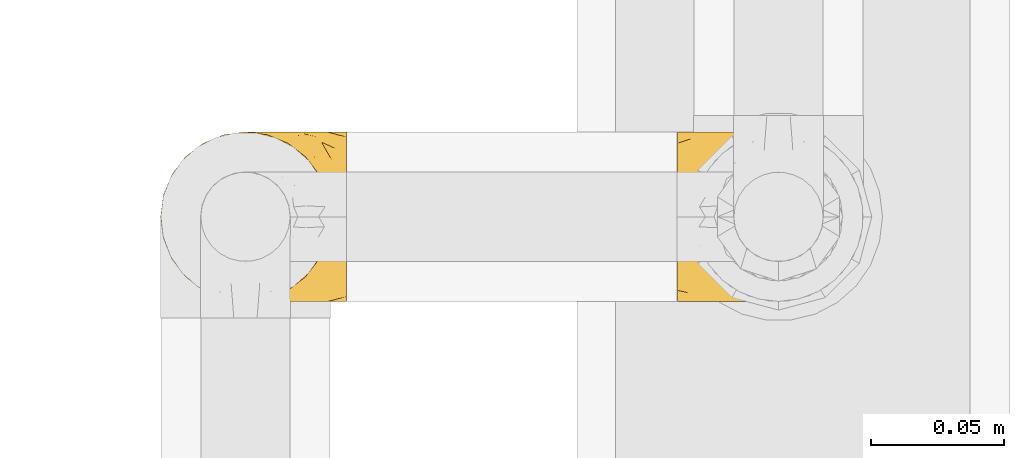
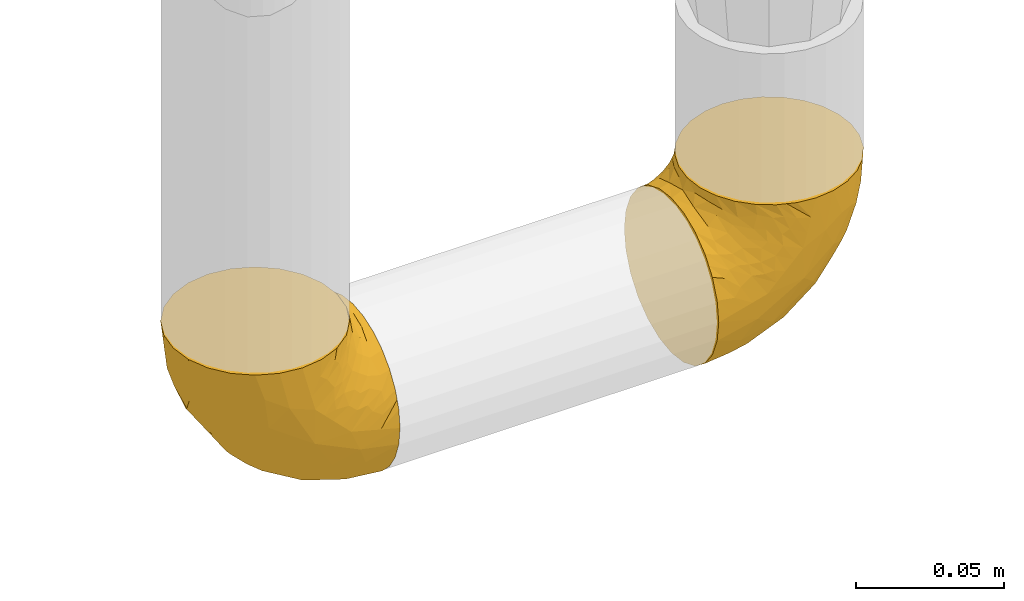
# One storey, part 505 of 827: 2 coverings.
"""IFC2X3 building model written with IfcOpenShell, lengths in millimetres."""

from ifc_helpers import new_model, entity, si_unit, converted_unit, derived_unit, direction, frame, origin, place, context, subcontext, project, spatial, faceted_brep, element, save


model = new_model("IFC2X3")

# Units and contexts
model_context = context("Model", 3, precision=0.01, world=origin(), true_north=direction((6.12303176911189e-17, 1.0)))
body_context = subcontext(model_context, "Body", "Model", "MODEL_VIEW")
ifc_project = project(units=[si_unit("LENGTHUNIT", "METRE", prefix="MILLI"), si_unit("AREAUNIT", "SQUARE_METRE"), si_unit("VOLUMEUNIT", "CUBIC_METRE"), converted_unit("PLANEANGLEUNIT", "DEGREE", entity("IfcRatioMeasure", 0.0174532925199433), si_unit("PLANEANGLEUNIT", "RADIAN"), dimensions=[0, 0, 0, 0, 0, 0, 0]), si_unit("MASSUNIT", "GRAM", prefix="KILO"), derived_unit("MASSDENSITYUNIT", [(si_unit("MASSUNIT", "GRAM", prefix="KILO"), 1), (si_unit("LENGTHUNIT", "METRE"), -3)]), derived_unit("MOMENTOFINERTIAUNIT", [(si_unit("LENGTHUNIT", "METRE"), 4)]), si_unit("TIMEUNIT", "SECOND"), si_unit("FREQUENCYUNIT", "HERTZ"), si_unit("THERMODYNAMICTEMPERATUREUNIT", "DEGREE_CELSIUS"), derived_unit("THERMALTRANSMITTANCEUNIT", [(si_unit("MASSUNIT", "GRAM", prefix="KILO"), 1), (si_unit("THERMODYNAMICTEMPERATUREUNIT", "KELVIN"), -1), (si_unit("TIMEUNIT", "SECOND"), -3)]), derived_unit("VOLUMETRICFLOWRATEUNIT", [(si_unit("LENGTHUNIT", "METRE"), 3), (si_unit("TIMEUNIT", "SECOND"), -1)]), derived_unit("MASSFLOWRATEUNIT", [(si_unit("MASSUNIT", "GRAM", prefix="KILO"), 1), (si_unit("TIMEUNIT", "SECOND"), -1)]), derived_unit("ROTATIONALFREQUENCYUNIT", [(si_unit("TIMEUNIT", "SECOND"), -1)]), si_unit("ELECTRICCURRENTUNIT", "AMPERE"), si_unit("ELECTRICVOLTAGEUNIT", "VOLT"), si_unit("POWERUNIT", "WATT"), si_unit("FORCEUNIT", "NEWTON", prefix="KILO"), si_unit("ILLUMINANCEUNIT", "LUX"), si_unit("LUMINOUSFLUXUNIT", "LUMEN"), si_unit("LUMINOUSINTENSITYUNIT", "CANDELA"), derived_unit("USERDEFINED", [(si_unit("MASSUNIT", "GRAM", prefix="KILO"), -1), (si_unit("LENGTHUNIT", "METRE"), -2), (si_unit("TIMEUNIT", "SECOND"), 3), (si_unit("LUMINOUSFLUXUNIT", "LUMEN"), 1)]), derived_unit("LINEARVELOCITYUNIT", [(si_unit("LENGTHUNIT", "METRE"), 1), (si_unit("TIMEUNIT", "SECOND"), -1)]), si_unit("PRESSUREUNIT", "PASCAL"), derived_unit("USERDEFINED", [(si_unit("LENGTHUNIT", "METRE"), -2), (si_unit("MASSUNIT", "GRAM", prefix="KILO"), 1), (si_unit("TIMEUNIT", "SECOND"), -2)]), derived_unit("LINEARFORCEUNIT", [(si_unit("MASSUNIT", "GRAM", prefix="KILO"), 1), (si_unit("LENGTHUNIT", "METRE"), 1), (si_unit("TIMEUNIT", "SECOND"), -2), (si_unit("LENGTHUNIT", "METRE"), -1)]), derived_unit("PLANARFORCEUNIT", [(si_unit("MASSUNIT", "GRAM", prefix="KILO"), 1), (si_unit("LENGTHUNIT", "METRE"), 1), (si_unit("TIMEUNIT", "SECOND"), -2), (si_unit("LENGTHUNIT", "METRE"), -2)])], contexts=[model_context])

# Site, building, storey
site_placement = place(None, origin())
site = spatial("IfcSite", under=ifc_project, at=site_placement, CompositionType="ELEMENT")
building_placement = place(site_placement, origin())
building = spatial("IfcBuilding", under=site, at=building_placement, CompositionType="ELEMENT")
storey_placement = place(building_placement, frame((0.0, 0.0, 28200.0)))
storey = spatial("IfcBuildingStorey", under=building, at=storey_placement, Name="08", CompositionType="ELEMENT", Elevation=28200.0)

# Coverings
covering_1_placement = place(storey_placement, frame((59919.69, 17466.55, 366.55)))
element("IfcCovering", 1, at=covering_1_placement, inside=storey, Name=":ADSK_", ObjectType=":ADSK_", PredefinedType="INSULATION", context=body_context, shape_type="Brep", body=[
    faceted_brep([(71.45, 26.36, 2.39), (71.45, 33.45, 1.6), (71.45, 40.54, 2.39), (71.45, 47.27, 4.75), (71.45, 53.31, 8.55), (71.45, 58.35, 13.59), (71.45, 62.14, 19.63), (71.45, 64.5, 26.36), (71.45, 65.3, 33.45), (71.45, 64.86, 37.35), (71.45, 64.5, 40.54), (71.45, 63.32, 43.9), (71.45, 62.14, 47.27), (71.45, 58.34, 53.31), (71.45, 53.3, 58.35), (71.45, 47.26, 62.14), (71.45, 40.53, 64.5), (71.45, 33.45, 65.3), (71.45, 26.35, 64.5), (71.45, 19.62, 62.14), (71.45, 13.58, 58.34), (71.45, 8.54, 53.3), (71.45, 4.75, 47.26), (71.45, 3.57, 43.89), (71.45, 2.39, 40.53), (71.45, 2.03, 37.35), (71.45, 1.81, 35.4), (71.45, 1.6, 33.45), (71.45, 2.39, 26.35), (71.45, 4.75, 19.62), (71.45, 8.55, 13.58), (71.45, 13.59, 8.54), (71.45, 19.63, 4.75), (49.37, 61.03, 71.45), (45.53, 62.62, 71.45), (41.69, 64.21, 71.45), (37.37, 64.78, 71.45), (35.41, 65.04, 71.45), (33.45, 65.3, 71.45), (25.2, 64.21, 71.45), (17.52, 61.03, 71.45), (10.92, 55.97, 71.45), (5.86, 49.37, 71.45), (2.68, 41.69, 71.45), (1.6, 33.45, 71.45), (2.68, 25.2, 71.45), (5.86, 17.52, 71.45), (10.92, 10.92, 71.45), (17.52, 5.86, 71.45), (25.2, 2.68, 71.45), (33.45, 1.6, 71.45), (37.37, 2.11, 71.45), (41.69, 2.68, 71.45), (45.53, 4.27, 71.45), (49.37, 5.86, 71.45), (52.67, 8.39, 71.45), (55.97, 10.92, 71.45), (61.03, 17.52, 71.45), (64.21, 25.2, 71.45), (65.3, 33.45, 71.45), (64.21, 41.69, 71.45), (61.03, 49.37, 71.45), (55.97, 55.97, 71.45), (52.67, 58.5, 71.45), (39.1, 2.87, 37.48), (52.45, 1.6, 38.54), (48.97, 1.6, 42.01), (45.49, 1.6, 45.49), (42.01, 1.6, 48.97), (38.54, 1.6, 52.45), (4.25, 33.45, 58.08), (19.42, 10.76, 40.84), (22.87, 5.89, 47.91), (14.43, 9.64, 55.67), (5.53, 22.45, 55.18), (12.01, 16.56, 45.13), (8.54, 15.17, 59.19), (55.06, 12.49, 11.67), (11.33, 25.02, 38.17), (20.79, 18.64, 28.82), (56.32, 2.29, 29.48), (33.95, 6.11, 32.11), (47.18, 5.18, 24.68), (28.97, 2.43, 55.82), (28.68, 11.11, 28.37), (41.69, 26.19, 9.18), (55.32, 24.02, 4.95), (43.59, 19.02, 11.17), (20.67, 4.77, 60.89), (37.76, 1.6, 55.35), (36.98, 1.6, 58.25), (36.2, 1.6, 61.15), (35.43, 1.6, 64.05), (34.93, 1.6, 65.9), (34.44, 1.6, 67.75), (58.97, 7.57, 16.27), (59.39, 17.54, 6.97), (58.08, 33.45, 4.25), (59.72, 4.36, 21.84), (69.6, 1.6, 33.94), (67.75, 1.6, 34.44), (64.05, 1.6, 35.43), (61.15, 1.6, 36.2), (58.25, 1.6, 36.98), (55.35, 1.6, 37.76), (43.85, 9.86, 18.84), (44.13, 14.05, 14.39), (4.87, 28.37, 51.68), (44.71, 33.45, 6.91), (19.59, 25.8, 26.05), (14.48, 33.45, 33.38), (22.05, 33.45, 22.05), (29.9, 22.54, 17.7), (33.81, 15.6, 19.21), (6.91, 33.45, 44.71), (27.44, 28.45, 17.7), (33.38, 33.45, 14.48), (55.01, 9.47, 66.98), (50.28, 5.83, 65.01), (51.09, 5.65, 61.98), (40.86, 2.31, 64.85), (43.96, 2.89, 62.15), (52.27, 2.68, 48.67), (68.29, 22.04, 63.81), (62.01, 5.47, 50.71), (66.26, 5.05, 48.45), (67.36, 7.86, 52.85), (65.34, 25.25, 67.6), (68.62, 28.09, 65.48), (67.1, 33.45, 67.1), (58.52, 12.77, 66.68), (61.41, 2.62, 43.2), (66.44, 3.56, 44.92), (65.71, 11.92, 58.1), (60.56, 11.98, 61.92), (65.05, 17.45, 63.17), (61.9, 17.1, 66.68), (58.97, 7.66, 56.7), (57.67, 4.47, 50.86), (62.23, 7.62, 54.42), (65.15, 2.29, 40.7), (46.86, 3.16, 57.76), (67.24, 16.64, 61.34), (63.1, 12.23, 59.9), (50.81, 4.54, 58.0), (54.65, 7.84, 62.43), (55.33, 2.55, 45.83), (56.17, 7.37, 58.99), (59.8, 3.18, 45.9), (48.09, 4.97, 67.3), (46.45, 2.38, 53.12), (46.88, 1.99, 49.43), (50.93, 3.56, 53.9), (55.61, 4.66, 52.92), (68.29, 44.85, 63.81), (67.24, 50.24, 61.35), (65.05, 49.43, 63.17), (58.97, 59.23, 56.72), (62.98, 54.76, 59.87), (61.5, 59.54, 54.39), (65.34, 41.64, 67.59), (65.15, 64.6, 40.71), (64.05, 65.3, 35.43), (61.15, 65.3, 36.2), (58.25, 65.3, 36.98), (68.62, 38.79, 65.48), (50.62, 62.38, 58.19), (45.09, 64.44, 55.78), (50.82, 61.27, 62.46), (33.94, 65.3, 69.6), (36.2, 65.3, 61.15), (35.43, 65.3, 64.05), (34.44, 65.3, 67.75), (51.55, 59.93, 67.39), (46.52, 62.73, 66.16), (54.95, 60.51, 58.11), (54.65, 59.05, 62.44), (59.16, 56.02, 61.95), (61.9, 49.79, 66.68), (40.86, 64.58, 64.85), (38.54, 65.3, 52.45), (42.01, 65.3, 48.97), (61.39, 64.27, 43.18), (67.37, 59.01, 52.88), (66.23, 61.84, 48.46), (67.75, 65.3, 34.44), (65.9, 65.3, 34.93), (65.7, 54.97, 58.11), (36.98, 65.3, 58.25), (41.66, 64.66, 60.72), (53.21, 63.94, 49.13), (45.49, 65.3, 45.49), (50.1, 63.6, 53.71), (66.44, 63.33, 44.93), (55.11, 57.32, 67.04), (58.52, 54.15, 66.6), (55.59, 64.5, 44.91), (62.01, 61.42, 50.72), (55.35, 65.3, 37.76), (52.45, 65.3, 38.54), (60.71, 63.43, 46.39), (42.77, 64.69, 57.7), (37.76, 65.3, 55.35), (47.15, 62.87, 62.73), (48.97, 65.3, 42.01), (14.42, 57.25, 55.67), (59.72, 62.54, 21.85), (56.32, 64.6, 29.49), (28.97, 64.46, 55.82), (11.33, 41.87, 38.17), (5.53, 44.44, 55.18), (12.01, 50.33, 45.12), (22.86, 61.0, 47.92), (39.12, 64.03, 37.47), (33.96, 60.79, 32.11), (19.42, 56.13, 40.85), (4.87, 38.52, 51.68), (20.67, 62.12, 60.89), (8.55, 51.72, 59.19), (47.18, 61.71, 24.69), (58.97, 59.33, 16.28), (43.86, 57.04, 18.85), (43.58, 47.88, 11.19), (55.32, 42.88, 4.95), (41.67, 40.71, 9.19), (55.05, 54.41, 11.68), (19.59, 41.09, 26.05), (33.79, 51.29, 19.23), (44.12, 52.85, 14.4), (59.39, 49.36, 6.97), (20.81, 48.25, 28.8), (29.91, 44.35, 17.7), (28.68, 55.79, 28.37), (27.45, 38.44, 17.7)], [[[0, 1, 2, 3, 4, 5, 6, 7, 8, 9, 10, 11, 12, 13, 14, 15, 16, 17, 18, 19, 20, 21, 22, 23, 24, 25, 26, 27, 28, 29, 30, 31, 32]], [[33, 34, 35, 36, 37, 38, 39, 40, 41, 42, 43, 44, 45, 46, 47, 48, 49, 50, 51, 52, 53, 54, 55, 56, 57, 58, 59, 60, 61, 62, 63]], [[64, 65, 66, 67, 68, 69]], [[45, 44, 70]], [[71, 72, 73]], [[74, 75, 76]], [[77, 31, 30]], [[75, 78, 79]], [[27, 80, 28]], [[74, 46, 45]], [[64, 81, 82]], [[46, 76, 47]], [[83, 50, 49]], [[48, 47, 73]], [[71, 79, 84]], [[85, 86, 87]], [[49, 48, 88]], [[83, 69, 89, 90, 91, 92, 93, 94, 50]], [[95, 77, 30]], [[75, 74, 78]], [[87, 86, 96]], [[96, 86, 32]], [[96, 32, 31]], [[0, 86, 97]], [[83, 64, 69]], [[98, 80, 82]], [[73, 72, 88]], [[64, 80, 65]], [[1, 0, 97]], [[80, 27, 99, 100, 101, 102, 103, 104, 65]], [[77, 105, 106]], [[64, 82, 80]], [[70, 107, 45]], [[77, 95, 105]], [[82, 95, 98]], [[95, 30, 29]], [[74, 107, 78]], [[86, 0, 32]], [[72, 71, 81]], [[85, 108, 86]], [[76, 73, 47]], [[71, 84, 81]], [[109, 110, 111]], [[87, 112, 85]], [[79, 109, 112]], [[79, 112, 113]], [[88, 83, 49]], [[64, 83, 72]], [[31, 77, 96]], [[87, 96, 77]], [[98, 95, 29]], [[105, 95, 82]], [[81, 105, 82]], [[105, 84, 113]], [[29, 28, 98]], [[114, 107, 70]], [[80, 98, 28]], [[73, 75, 71]], [[79, 71, 75]], [[74, 76, 46]], [[73, 76, 75]], [[78, 107, 114]], [[45, 107, 74]], [[87, 113, 112]], [[115, 85, 112]], [[109, 79, 78]], [[113, 87, 106]], [[116, 115, 111]], [[116, 108, 85]], [[79, 113, 84]], [[109, 78, 110]], [[115, 109, 111]], [[85, 115, 116]], [[109, 115, 112]], [[72, 81, 64]], [[105, 81, 84]], [[73, 88, 48]], [[83, 88, 72]], [[86, 108, 97]], [[78, 114, 110]], [[113, 106, 105]], [[87, 77, 106]], [[117, 118, 119]], [[52, 120, 54, 53]], [[91, 120, 52]], [[91, 90, 120]], [[90, 121, 120]], [[122, 67, 66]], [[18, 123, 19]], [[124, 125, 126]], [[127, 59, 58]], [[128, 129, 127]], [[130, 57, 117]], [[131, 132, 125]], [[19, 133, 20]], [[128, 18, 17]], [[134, 135, 136]], [[137, 138, 139]], [[131, 103, 140]], [[22, 140, 23]], [[131, 65, 104, 103]], [[26, 25, 24, 101, 100, 99, 27]], [[141, 118, 121]], [[19, 123, 142]], [[52, 51, 50, 94, 93, 92, 91]], [[129, 128, 17]], [[117, 56, 118]], [[135, 134, 143]], [[139, 126, 133]], [[119, 144, 145]], [[127, 135, 123]], [[136, 58, 57]], [[101, 24, 23]], [[124, 138, 146]], [[140, 101, 23]], [[145, 147, 134]], [[140, 132, 131]], [[140, 103, 102, 101]], [[140, 22, 132]], [[146, 148, 124]], [[121, 69, 141]], [[55, 149, 118]], [[150, 151, 152]], [[147, 137, 134]], [[144, 150, 152]], [[152, 151, 122]], [[138, 122, 146]], [[59, 127, 129]], [[123, 18, 128]], [[58, 136, 127]], [[135, 127, 136]], [[121, 90, 89, 69]], [[120, 121, 149]], [[122, 66, 146]], [[153, 122, 138]], [[141, 69, 68]], [[127, 123, 128]], [[123, 135, 142]], [[143, 142, 135]], [[19, 142, 133]], [[66, 65, 146]], [[148, 65, 131]], [[22, 21, 132]], [[125, 132, 21]], [[126, 125, 21]], [[148, 125, 124]], [[21, 20, 126]], [[133, 126, 20]], [[139, 138, 124]], [[153, 138, 137]], [[126, 139, 124]], [[139, 133, 143]], [[147, 153, 137]], [[152, 122, 153]], [[134, 136, 130]], [[137, 139, 143]], [[144, 147, 145]], [[153, 147, 152]], [[65, 148, 146]], [[125, 148, 131]], [[141, 144, 119]], [[55, 54, 149]], [[137, 143, 134]], [[142, 143, 133]], [[130, 117, 145]], [[57, 56, 117]], [[134, 130, 145]], [[57, 130, 136]], [[150, 144, 141]], [[147, 144, 152]], [[141, 68, 150]], [[151, 68, 67]], [[117, 119, 145]], [[141, 119, 118]], [[68, 151, 150]], [[122, 151, 67]], [[118, 56, 55]], [[120, 149, 54]], [[118, 149, 121]], [[154, 155, 156]], [[157, 158, 159]], [[129, 160, 59]], [[161, 162, 163, 164]], [[165, 160, 129]], [[166, 167, 168]], [[169, 38, 37, 36, 35, 170, 171, 172]], [[63, 173, 174]], [[175, 176, 177]], [[60, 178, 61]], [[179, 35, 34, 33]], [[160, 60, 59]], [[180, 167, 181]], [[129, 17, 165]], [[182, 161, 164]], [[183, 13, 184]], [[9, 8, 185, 186, 162, 10]], [[187, 155, 15]], [[188, 179, 189]], [[187, 15, 14]], [[190, 191, 192]], [[182, 193, 161]], [[194, 176, 168]], [[176, 195, 177]], [[196, 190, 197]], [[11, 10, 162]], [[11, 161, 12]], [[187, 14, 183]], [[12, 161, 193]], [[156, 158, 177]], [[165, 17, 16]], [[194, 195, 176]], [[187, 159, 158]], [[179, 174, 189]], [[182, 164, 198, 199]], [[200, 199, 196]], [[193, 184, 13]], [[194, 168, 173]], [[201, 202, 189]], [[16, 154, 165]], [[160, 156, 178]], [[160, 165, 154]], [[178, 60, 160]], [[170, 35, 179]], [[188, 170, 179]], [[189, 174, 203]], [[174, 179, 33]], [[201, 189, 203]], [[181, 192, 191]], [[167, 180, 201]], [[192, 175, 190]], [[159, 190, 157]], [[15, 154, 16]], [[204, 196, 199]], [[204, 191, 190]], [[160, 154, 156]], [[15, 155, 154]], [[158, 155, 187]], [[203, 173, 168]], [[192, 181, 167]], [[190, 196, 204]], [[200, 196, 197]], [[184, 193, 182]], [[13, 12, 193]], [[200, 184, 182]], [[184, 200, 183]], [[187, 183, 197]], [[14, 13, 183]], [[162, 161, 11]], [[63, 62, 173]], [[174, 33, 63]], [[173, 62, 194]], [[174, 173, 203]], [[62, 61, 194]], [[195, 61, 178]], [[61, 195, 194]], [[177, 195, 178]], [[156, 177, 178]], [[175, 192, 166]], [[166, 168, 176]], [[167, 203, 168]], [[175, 166, 176]], [[167, 166, 192]], [[177, 157, 175]], [[190, 175, 157]], [[187, 197, 159]], [[190, 159, 197]], [[177, 158, 157]], [[155, 158, 156]], [[167, 201, 203]], [[200, 197, 183]], [[202, 201, 180]], [[202, 188, 189]], [[199, 200, 182]], [[41, 40, 205]], [[206, 207, 7]], [[208, 38, 169, 172, 171, 170, 188, 202, 180]], [[209, 210, 211]], [[212, 213, 214]], [[212, 215, 205]], [[43, 210, 216]], [[217, 40, 39]], [[216, 114, 70]], [[208, 213, 212]], [[205, 40, 217]], [[218, 42, 41]], [[216, 209, 114]], [[42, 218, 210]], [[214, 213, 219]], [[219, 220, 221]], [[199, 207, 213]], [[213, 207, 219]], [[8, 7, 207]], [[222, 223, 224]], [[4, 225, 5]], [[2, 97, 223]], [[110, 226, 111]], [[225, 220, 5]], [[227, 221, 228]], [[223, 229, 3]], [[2, 223, 3]], [[230, 231, 226]], [[224, 223, 108]], [[42, 210, 43]], [[230, 209, 211]], [[222, 225, 229]], [[38, 208, 39]], [[3, 229, 4]], [[213, 180, 181, 191, 204, 199]], [[220, 206, 6]], [[5, 220, 6]], [[207, 199, 198, 164, 163, 162, 186, 185, 8]], [[212, 214, 215]], [[218, 205, 211]], [[211, 215, 230]], [[226, 110, 209]], [[222, 231, 227]], [[222, 224, 231]], [[213, 208, 180]], [[217, 208, 212]], [[222, 229, 223]], [[225, 4, 229]], [[221, 220, 225]], [[206, 220, 219]], [[228, 221, 225]], [[214, 221, 232]], [[207, 206, 219]], [[44, 43, 70]], [[7, 6, 206]], [[230, 215, 232]], [[211, 205, 215]], [[205, 218, 41]], [[210, 218, 211]], [[43, 216, 70]], [[209, 216, 210]], [[233, 116, 111]], [[230, 232, 227]], [[224, 116, 233]], [[230, 226, 209]], [[224, 108, 116]], [[230, 227, 231]], [[221, 227, 232]], [[233, 226, 231]], [[225, 222, 228]], [[226, 233, 111]], [[224, 233, 231]], [[221, 214, 219]], [[214, 232, 215]], [[208, 217, 39]], [[205, 217, 212]], [[97, 2, 1]], [[97, 108, 223]], [[110, 114, 209]], [[227, 228, 222]]]),
])
covering_2_placement = place(storey_placement, frame((60113.54, 17466.55, 366.55)))
element("IfcCovering", 2, at=covering_2_placement, inside=storey, Name=":ADSK_", ObjectType=":ADSK_", PredefinedType="INSULATION", context=body_context, shape_type="Brep", body=[
    faceted_brep([(70.65, 26.36, 71.45), (71.45, 33.45, 71.45), (70.65, 40.54, 71.45), (68.29, 47.27, 71.45), (64.49, 53.31, 71.45), (59.45, 58.35, 71.45), (53.41, 62.14, 71.45), (46.68, 64.5, 71.45), (39.6, 65.3, 71.45), (35.69, 64.86, 71.45), (32.5, 64.5, 71.45), (29.14, 63.32, 71.45), (25.77, 62.14, 71.45), (19.73, 58.34, 71.45), (14.69, 53.3, 71.45), (10.9, 47.26, 71.45), (8.54, 40.53, 71.45), (7.75, 33.45, 71.45), (8.54, 26.35, 71.45), (10.9, 19.62, 71.45), (14.7, 13.58, 71.45), (19.74, 8.54, 71.45), (25.78, 4.75, 71.45), (29.15, 3.57, 71.45), (32.51, 2.39, 71.45), (35.69, 2.03, 71.45), (37.64, 1.81, 71.45), (39.6, 1.6, 71.45), (46.69, 2.39, 71.45), (53.42, 4.75, 71.45), (59.46, 8.55, 71.45), (64.5, 13.59, 71.45), (68.29, 19.63, 71.45), (1.6, 61.03, 49.37), (1.6, 62.62, 45.53), (1.6, 64.21, 41.69), (1.6, 64.78, 37.37), (1.6, 65.04, 35.41), (1.6, 65.3, 33.45), (1.6, 64.21, 25.2), (1.6, 61.03, 17.52), (1.6, 55.97, 10.92), (1.6, 49.37, 5.86), (1.6, 41.69, 2.68), (1.6, 33.45, 1.6), (1.6, 25.2, 2.68), (1.6, 17.52, 5.86), (1.6, 10.92, 10.92), (1.6, 5.86, 17.52), (1.6, 2.68, 25.2), (1.6, 1.6, 33.45), (1.6, 2.11, 37.37), (1.6, 2.68, 41.69), (1.6, 4.27, 45.53), (1.6, 5.86, 49.37), (1.6, 8.39, 52.67), (1.6, 10.92, 55.97), (1.6, 17.52, 61.03), (1.6, 25.2, 64.21), (1.6, 33.45, 65.3), (1.6, 41.69, 64.21), (1.6, 49.37, 61.03), (1.6, 55.97, 55.97), (1.6, 58.5, 52.67), (35.56, 2.87, 39.1), (34.5, 1.6, 52.45), (31.03, 1.6, 48.97), (27.55, 1.6, 45.49), (24.07, 1.6, 42.01), (20.6, 1.6, 38.54), (14.96, 33.45, 4.25), (32.2, 10.76, 19.42), (25.13, 5.89, 22.87), (17.37, 9.64, 14.43), (17.86, 22.45, 5.53), (27.91, 16.56, 12.01), (13.85, 15.17, 8.54), (61.37, 12.49, 55.06), (34.87, 25.02, 11.33), (44.22, 18.64, 20.79), (43.56, 2.29, 56.32), (40.93, 6.11, 33.95), (48.36, 5.18, 47.18), (17.22, 2.43, 28.97), (44.67, 11.11, 28.68), (63.86, 26.19, 41.69), (68.09, 24.02, 55.32), (61.87, 19.02, 43.59), (12.15, 4.77, 20.67), (17.69, 1.6, 37.76), (14.79, 1.6, 36.98), (11.89, 1.6, 36.2), (8.99, 1.6, 35.43), (7.14, 1.6, 34.93), (5.29, 1.6, 34.44), (56.77, 7.57, 58.97), (66.08, 17.54, 59.39), (68.79, 33.45, 58.08), (51.2, 4.36, 59.72), (39.1, 1.6, 69.6), (38.61, 1.6, 67.75), (37.61, 1.6, 64.05), (36.84, 1.6, 61.15), (36.06, 1.6, 58.25), (35.28, 1.6, 55.35), (54.2, 9.86, 43.85), (58.65, 14.05, 44.13), (21.36, 28.37, 4.87), (66.13, 33.45, 44.71), (46.99, 25.8, 19.59), (39.66, 33.45, 14.48), (50.99, 33.45, 22.05), (55.34, 22.54, 29.9), (53.83, 15.6, 33.81), (28.33, 33.45, 6.91), (55.34, 28.45, 27.44), (58.56, 33.45, 33.38), (6.06, 9.47, 55.01), (8.03, 5.83, 50.28), (11.06, 5.65, 51.09), (8.19, 2.31, 40.86), (10.89, 2.89, 43.96), (24.37, 2.68, 52.27), (9.23, 22.04, 68.29), (22.33, 5.47, 62.01), (24.59, 5.05, 66.26), (20.19, 7.86, 67.36), (5.45, 25.25, 65.34), (7.56, 28.09, 68.62), (5.94, 33.45, 67.1), (6.36, 12.77, 58.52), (29.84, 2.62, 61.41), (28.12, 3.56, 66.44), (14.94, 11.92, 65.71), (11.12, 11.98, 60.56), (9.87, 17.45, 65.05), (6.36, 17.1, 61.9), (16.34, 7.66, 58.97), (22.18, 4.47, 57.67), (18.62, 7.62, 62.23), (32.34, 2.29, 65.15), (15.29, 3.16, 46.86), (11.7, 16.64, 67.24), (13.14, 12.23, 63.1), (15.04, 4.54, 50.81), (10.61, 7.84, 54.65), (27.21, 2.55, 55.33), (14.05, 7.37, 56.17), (27.14, 3.18, 59.8), (5.74, 4.97, 48.09), (19.92, 2.38, 46.45), (23.61, 1.99, 46.88), (19.14, 3.56, 50.93), (20.12, 4.66, 55.61), (9.23, 44.85, 68.29), (11.69, 50.24, 67.24), (9.87, 49.43, 65.05), (16.33, 59.23, 58.97), (13.17, 54.76, 62.98), (18.65, 59.54, 61.5), (5.45, 41.64, 65.34), (32.33, 64.6, 65.15), (37.61, 65.3, 64.05), (36.84, 65.3, 61.15), (36.06, 65.3, 58.25), (7.56, 38.79, 68.62), (14.85, 62.38, 50.62), (17.26, 64.44, 45.09), (10.58, 61.27, 50.82), (3.44, 65.3, 33.94), (11.89, 65.3, 36.2), (8.99, 65.3, 35.43), (5.29, 65.3, 34.44), (5.65, 59.93, 51.55), (6.88, 62.73, 46.52), (14.93, 60.51, 54.95), (10.6, 59.05, 54.65), (11.09, 56.02, 59.16), (6.36, 49.79, 61.9), (8.19, 64.58, 40.86), (20.6, 65.3, 38.54), (24.07, 65.3, 42.01), (29.86, 64.27, 61.39), (20.16, 59.01, 67.37), (24.58, 61.84, 66.23), (38.61, 65.3, 67.75), (38.11, 65.3, 65.9), (14.93, 54.97, 65.7), (14.79, 65.3, 36.98), (12.32, 64.66, 41.66), (23.91, 63.94, 53.21), (27.55, 65.3, 45.49), (19.33, 63.6, 50.1), (28.11, 63.33, 66.44), (6.0, 57.32, 55.11), (6.44, 54.15, 58.52), (28.13, 64.5, 55.59), (22.32, 61.42, 62.01), (35.28, 65.3, 55.35), (34.5, 65.3, 52.45), (26.65, 63.43, 60.71), (15.34, 64.69, 42.77), (17.69, 65.3, 37.76), (10.31, 62.87, 47.15), (31.03, 65.3, 48.97), (17.37, 57.25, 14.42), (51.19, 62.54, 59.72), (43.56, 64.6, 56.32), (17.22, 64.46, 28.97), (34.87, 41.87, 11.33), (17.86, 44.44, 5.53), (27.92, 50.33, 12.01), (25.12, 61.0, 22.86), (35.57, 64.03, 39.12), (40.93, 60.79, 33.96), (32.19, 56.13, 19.42), (21.36, 38.52, 4.87), (12.15, 62.12, 20.67), (13.85, 51.72, 8.55), (48.35, 61.71, 47.18), (56.76, 59.33, 58.97), (54.19, 57.04, 43.86), (61.86, 47.88, 43.58), (68.09, 42.88, 55.32), (63.85, 40.71, 41.67), (61.36, 54.41, 55.05), (47.0, 41.09, 19.59), (53.81, 51.29, 33.79), (58.64, 52.85, 44.12), (66.07, 49.36, 59.39), (44.24, 48.25, 20.81), (55.34, 44.35, 29.91), (44.67, 55.79, 28.68), (55.34, 38.44, 27.45)], [[[0, 1, 2, 3, 4, 5, 6, 7, 8, 9, 10, 11, 12, 13, 14, 15, 16, 17, 18, 19, 20, 21, 22, 23, 24, 25, 26, 27, 28, 29, 30, 31, 32]], [[33, 34, 35, 36, 37, 38, 39, 40, 41, 42, 43, 44, 45, 46, 47, 48, 49, 50, 51, 52, 53, 54, 55, 56, 57, 58, 59, 60, 61, 62, 63]], [[64, 65, 66, 67, 68, 69]], [[45, 44, 70]], [[71, 72, 73]], [[74, 75, 76]], [[77, 31, 30]], [[75, 78, 79]], [[27, 80, 28]], [[74, 46, 45]], [[64, 81, 82]], [[46, 76, 47]], [[83, 50, 49]], [[48, 47, 73]], [[71, 79, 84]], [[85, 86, 87]], [[49, 48, 88]], [[83, 69, 89, 90, 91, 92, 93, 94, 50]], [[95, 77, 30]], [[75, 74, 78]], [[87, 86, 96]], [[96, 86, 32]], [[96, 32, 31]], [[0, 86, 97]], [[83, 64, 69]], [[98, 80, 82]], [[73, 72, 88]], [[64, 80, 65]], [[1, 0, 97]], [[80, 27, 99, 100, 101, 102, 103, 104, 65]], [[77, 105, 106]], [[64, 82, 80]], [[70, 107, 45]], [[77, 95, 105]], [[82, 95, 98]], [[95, 30, 29]], [[74, 107, 78]], [[86, 0, 32]], [[72, 71, 81]], [[85, 108, 86]], [[76, 73, 47]], [[71, 84, 81]], [[109, 110, 111]], [[87, 112, 85]], [[79, 109, 112]], [[79, 112, 113]], [[88, 83, 49]], [[64, 83, 72]], [[31, 77, 96]], [[87, 96, 77]], [[98, 95, 29]], [[105, 95, 82]], [[81, 105, 82]], [[105, 84, 113]], [[29, 28, 98]], [[114, 107, 70]], [[80, 98, 28]], [[73, 75, 71]], [[79, 71, 75]], [[74, 76, 46]], [[73, 76, 75]], [[78, 107, 114]], [[45, 107, 74]], [[87, 113, 112]], [[115, 85, 112]], [[109, 79, 78]], [[113, 87, 106]], [[116, 115, 111]], [[116, 108, 85]], [[79, 113, 84]], [[109, 78, 110]], [[115, 109, 111]], [[85, 115, 116]], [[109, 115, 112]], [[72, 81, 64]], [[105, 81, 84]], [[73, 88, 48]], [[83, 88, 72]], [[86, 108, 97]], [[78, 114, 110]], [[113, 106, 105]], [[87, 77, 106]], [[117, 118, 119]], [[52, 120, 54, 53]], [[91, 120, 52]], [[91, 90, 120]], [[90, 121, 120]], [[122, 67, 66]], [[18, 123, 19]], [[124, 125, 126]], [[127, 59, 58]], [[128, 129, 127]], [[130, 57, 117]], [[131, 132, 125]], [[19, 133, 20]], [[128, 18, 17]], [[134, 135, 136]], [[137, 138, 139]], [[131, 103, 140]], [[22, 140, 23]], [[131, 65, 104, 103]], [[99, 27, 26, 25, 24, 101, 100]], [[141, 118, 121]], [[19, 123, 142]], [[52, 51, 50, 94, 93, 92, 91]], [[129, 128, 17]], [[117, 56, 118]], [[135, 134, 143]], [[139, 126, 133]], [[119, 144, 145]], [[127, 135, 123]], [[136, 58, 57]], [[101, 24, 23]], [[124, 138, 146]], [[140, 101, 23]], [[145, 147, 134]], [[140, 132, 131]], [[140, 103, 102, 101]], [[140, 22, 132]], [[146, 148, 124]], [[121, 69, 141]], [[55, 149, 118]], [[150, 151, 152]], [[147, 137, 134]], [[144, 150, 152]], [[152, 151, 122]], [[138, 122, 146]], [[59, 127, 129]], [[123, 18, 128]], [[58, 136, 127]], [[135, 127, 136]], [[121, 90, 89, 69]], [[120, 121, 149]], [[122, 66, 146]], [[153, 122, 138]], [[141, 69, 68]], [[127, 123, 128]], [[123, 135, 142]], [[143, 142, 135]], [[19, 142, 133]], [[66, 65, 146]], [[148, 65, 131]], [[22, 21, 132]], [[125, 132, 21]], [[126, 125, 21]], [[148, 125, 124]], [[21, 20, 126]], [[133, 126, 20]], [[139, 138, 124]], [[153, 138, 137]], [[126, 139, 124]], [[139, 133, 143]], [[147, 153, 137]], [[152, 122, 153]], [[134, 136, 130]], [[137, 139, 143]], [[144, 147, 145]], [[153, 147, 152]], [[65, 148, 146]], [[125, 148, 131]], [[141, 144, 119]], [[55, 54, 149]], [[137, 143, 134]], [[142, 143, 133]], [[130, 117, 145]], [[57, 56, 117]], [[134, 130, 145]], [[57, 130, 136]], [[150, 144, 141]], [[147, 144, 152]], [[141, 68, 150]], [[151, 68, 67]], [[117, 119, 145]], [[141, 119, 118]], [[68, 151, 150]], [[122, 151, 67]], [[118, 56, 55]], [[120, 149, 54]], [[118, 149, 121]], [[154, 155, 156]], [[157, 158, 159]], [[129, 160, 59]], [[161, 162, 163, 164]], [[165, 160, 129]], [[166, 167, 168]], [[169, 38, 37, 36, 35, 170, 171, 172]], [[63, 173, 174]], [[175, 176, 177]], [[60, 178, 61]], [[179, 35, 34, 33]], [[160, 60, 59]], [[180, 167, 181]], [[129, 17, 165]], [[182, 161, 164]], [[183, 13, 184]], [[9, 8, 185, 186, 162, 10]], [[187, 155, 15]], [[188, 179, 189]], [[187, 15, 14]], [[190, 191, 192]], [[182, 193, 161]], [[194, 176, 168]], [[176, 195, 177]], [[196, 190, 197]], [[11, 10, 162]], [[11, 161, 12]], [[187, 14, 183]], [[12, 161, 193]], [[156, 158, 177]], [[165, 17, 16]], [[194, 195, 176]], [[187, 159, 158]], [[179, 174, 189]], [[182, 164, 198, 199]], [[200, 199, 196]], [[193, 184, 13]], [[194, 168, 173]], [[201, 202, 189]], [[16, 154, 165]], [[160, 156, 178]], [[160, 165, 154]], [[178, 60, 160]], [[170, 35, 179]], [[188, 170, 179]], [[189, 174, 203]], [[174, 179, 33]], [[201, 189, 203]], [[181, 192, 191]], [[167, 180, 201]], [[192, 175, 190]], [[159, 190, 157]], [[15, 154, 16]], [[204, 196, 199]], [[204, 191, 190]], [[160, 154, 156]], [[15, 155, 154]], [[158, 155, 187]], [[203, 173, 168]], [[192, 181, 167]], [[190, 196, 204]], [[200, 196, 197]], [[184, 193, 182]], [[13, 12, 193]], [[200, 184, 182]], [[184, 200, 183]], [[187, 183, 197]], [[14, 13, 183]], [[162, 161, 11]], [[63, 62, 173]], [[174, 33, 63]], [[173, 62, 194]], [[174, 173, 203]], [[62, 61, 194]], [[195, 61, 178]], [[61, 195, 194]], [[177, 195, 178]], [[156, 177, 178]], [[175, 192, 166]], [[166, 168, 176]], [[167, 203, 168]], [[175, 166, 176]], [[167, 166, 192]], [[177, 157, 175]], [[190, 175, 157]], [[187, 197, 159]], [[190, 159, 197]], [[177, 158, 157]], [[155, 158, 156]], [[167, 201, 203]], [[200, 197, 183]], [[202, 201, 180]], [[202, 188, 189]], [[199, 200, 182]], [[41, 40, 205]], [[206, 207, 7]], [[208, 38, 169, 172, 171, 170, 188, 202, 180]], [[209, 210, 211]], [[212, 213, 214]], [[212, 215, 205]], [[43, 210, 216]], [[217, 40, 39]], [[216, 114, 70]], [[208, 213, 212]], [[205, 40, 217]], [[218, 42, 41]], [[216, 209, 114]], [[42, 218, 210]], [[214, 213, 219]], [[219, 220, 221]], [[199, 207, 213]], [[213, 207, 219]], [[8, 7, 207]], [[222, 223, 224]], [[4, 225, 5]], [[2, 97, 223]], [[110, 226, 111]], [[225, 220, 5]], [[227, 221, 228]], [[223, 229, 3]], [[2, 223, 3]], [[230, 231, 226]], [[224, 223, 108]], [[42, 210, 43]], [[230, 209, 211]], [[222, 225, 229]], [[38, 208, 39]], [[3, 229, 4]], [[213, 180, 181, 191, 204, 199]], [[220, 206, 6]], [[5, 220, 6]], [[207, 199, 198, 164, 163, 162, 186, 185, 8]], [[212, 214, 215]], [[218, 205, 211]], [[211, 215, 230]], [[226, 110, 209]], [[222, 231, 227]], [[222, 224, 231]], [[213, 208, 180]], [[217, 208, 212]], [[222, 229, 223]], [[225, 4, 229]], [[221, 220, 225]], [[206, 220, 219]], [[228, 221, 225]], [[214, 221, 232]], [[207, 206, 219]], [[44, 43, 70]], [[7, 6, 206]], [[230, 215, 232]], [[211, 205, 215]], [[205, 218, 41]], [[210, 218, 211]], [[43, 216, 70]], [[209, 216, 210]], [[233, 116, 111]], [[230, 232, 227]], [[224, 116, 233]], [[230, 226, 209]], [[224, 108, 116]], [[230, 227, 231]], [[221, 227, 232]], [[233, 226, 231]], [[225, 222, 228]], [[226, 233, 111]], [[224, 233, 231]], [[221, 214, 219]], [[214, 232, 215]], [[208, 217, 39]], [[205, 217, 212]], [[97, 2, 1]], [[97, 108, 223]], [[110, 114, 209]], [[227, 228, 222]]]),
])

save(model, "model.ifc")
